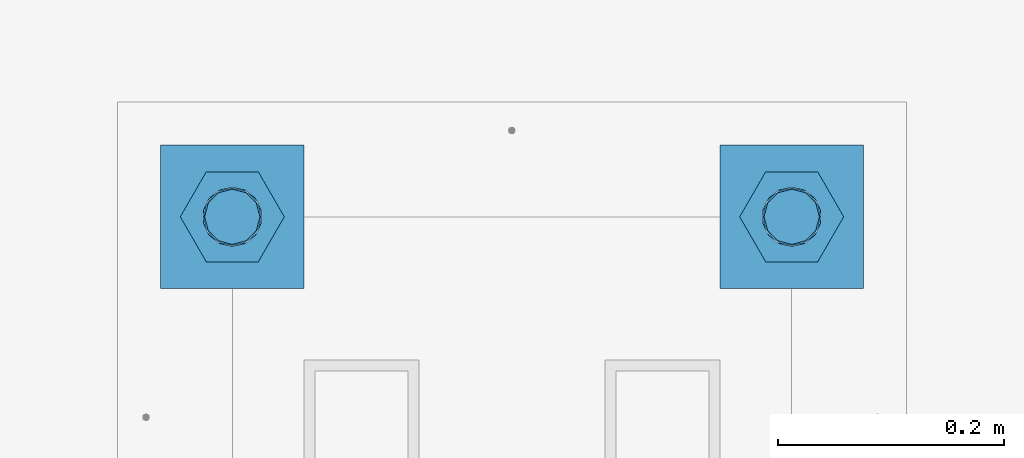
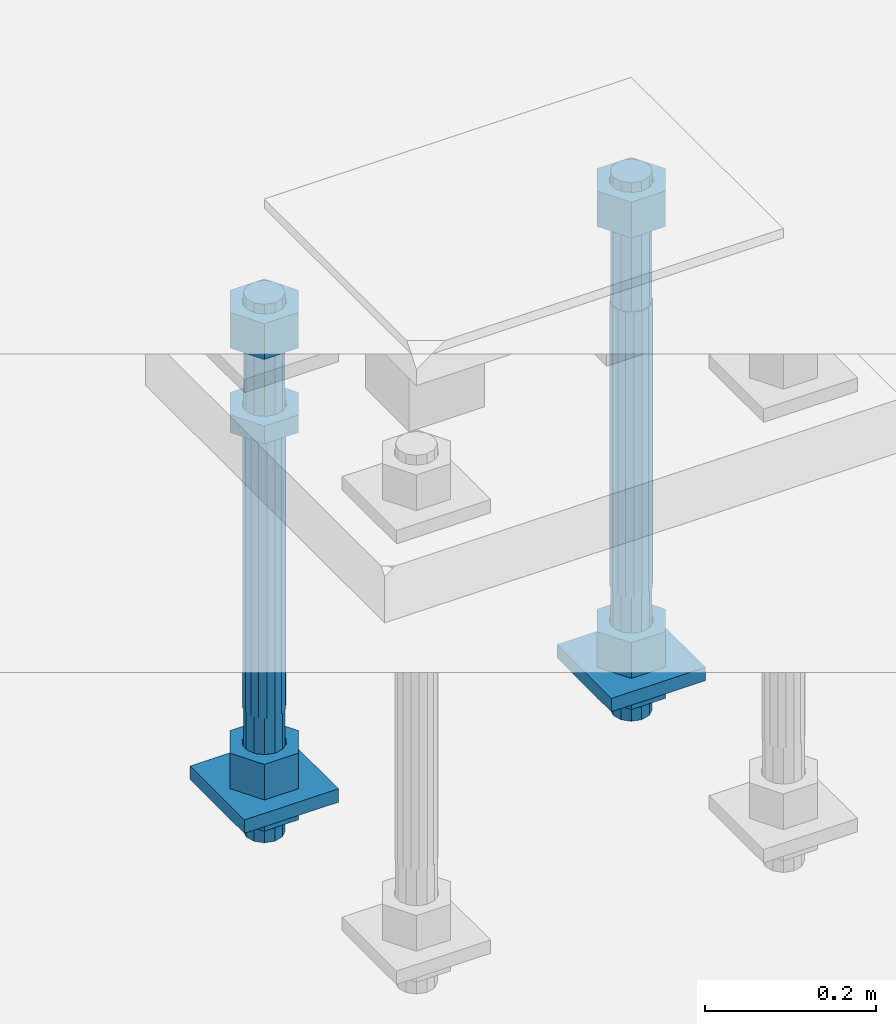
# One storey, part 2705 of 3843: 11 beams, 1 element without a shape of its own.
"""IFC2X3 building model written with IfcOpenShell, lengths in millimetres."""

from ifc_helpers import new_model, si_unit, frame, origin_with_axes, place, context, subcontext, project, spatial, faceted_brep, material, type_object, element, aggregate, save


model = new_model("IFC2X3")

# Units and contexts
model_context = context("Model", 3, precision=1e-05, world=origin_with_axes())
body_context = subcontext(model_context, "Body", "Model", "MODEL_VIEW")
ifc_project = project(units=[si_unit("LENGTHUNIT", "METRE", prefix="MILLI"), si_unit("AREAUNIT", "SQUARE_METRE"), si_unit("VOLUMEUNIT", "CUBIC_METRE"), si_unit("MASSUNIT", "GRAM", prefix="KILO"), si_unit("TIMEUNIT", "SECOND"), si_unit("PLANEANGLEUNIT", "RADIAN"), si_unit("SOLIDANGLEUNIT", "STERADIAN"), si_unit("THERMODYNAMICTEMPERATUREUNIT", "DEGREE_CELSIUS"), si_unit("LUMINOUSINTENSITYUNIT", "LUMEN")], contexts=[model_context])

# Site, building, storey
site_placement = place(None, origin_with_axes())
site = spatial("IfcSite", under=ifc_project, at=site_placement, CompositionType="ELEMENT")
building_placement = place(site_placement, origin_with_axes())
building = spatial("IfcBuilding", under=site, at=building_placement, Name="Undefined", CompositionType="ELEMENT")
storey_placement = place(building_placement, origin_with_axes())
storey = spatial("IfcBuildingStorey", under=building, at=storey_placement, Name="Undefined", CompositionType="ELEMENT", Elevation=0.0)

# Assembly, beams
assembly_placement = place(storey_placement, origin_with_axes())
assembly = element("IfcElementAssembly", 1, at=assembly_placement, inside=storey, Name="TEMPLATE", AssemblyPlace="NOTDEFINED", PredefinedType="RIGID_FRAME")
ifc_material_1 = material(Name="STEEL/A572-50")
beam_type_1 = type_object("IfcBeamType", PredefinedType="NOTDEFINED")
beam_1_placement = place(assembly_placement, frame((105403.65, 45910.4999984741, 29244.925), z_axis=(-1.0, 0.0, 0.0), x_axis=(0.0, -1.0, 0.0)))
beam_1 = element("IfcBeam", 2, at=beam_1_placement, type_object=beam_type_1, material=ifc_material_1, Name="WASHER_PLATE", context=body_context, shape_type="Brep", body=[
    faceted_brep([(0.0, 9.52500000000146, -63.5), (0.0, 9.52500000000146, 63.5), (127.0, 9.52500000000146, 63.5), (127.0, 9.52500000000146, -63.5), (0.0, -9.52500000000146, 63.5), (127.0, -9.52500000000146, 63.5), (0.0, -9.52500000000146, -63.5), (127.0, -9.52500000000146, -63.5)], [[[0, 1, 2, 3]], [[1, 4, 5, 2]], [[4, 6, 7, 5]], [[6, 0, 3, 7]], [[5, 7, 3, 2]], [[6, 4, 1, 0]]]),
])
beam_2_placement = place(assembly_placement, frame((104908.35, 45910.4999984741, 29244.925), z_axis=(-1.0, 0.0, 0.0), x_axis=(0.0, -1.0, 0.0)))
beam_2 = element("IfcBeam", 3, at=beam_2_placement, type_object=beam_type_1, material=ifc_material_1, Name="WASHER_PLATE", context=body_context, shape_type="Brep", body=[
    faceted_brep([(0.0, 9.52500000000146, -63.5), (0.0, 9.52500000000146, 63.5), (127.0, 9.52500000000146, 63.5), (127.0, 9.52500000000146, -63.5), (0.0, -9.52500000000146, 63.5), (127.0, -9.52500000000146, 63.5), (0.0, -9.52500000000146, -63.5), (127.0, -9.52500000000146, -63.5)], [[[0, 1, 2, 3]], [[1, 4, 5, 2]], [[4, 6, 7, 5]], [[6, 0, 3, 7]], [[5, 7, 3, 2]], [[6, 4, 1, 0]]]),
])
ifc_material_2 = material(Name="STEEL/A36")
beam_type_2 = type_object("IfcBeamType", Name="2_HALF_NUT", PredefinedType="NOTDEFINED")
beam_3_placement = place(assembly_placement, frame((105403.65, 45846.9999984741, 29235.4), z_axis=(0.0, -1.0, 0.0), x_axis=(0.0, 0.0, -1.0)))
beam_3 = element("IfcBeam", 4, at=beam_3_placement, type_object=beam_type_2, material=ifc_material_2, Name="NUT", ObjectType="2_HALF_NUT", context=body_context, shape_type="Brep", body=[
    faceted_brep([(0.0, -46.0369987487793, 0.0), (0.0, -23.0184993743896, -39.869213104248), (25.4000000000015, -23.0184993743896, -39.869213104248), (25.4000000000015, -46.0369987487793, 0.0), (0.0, 23.0184993743896, -39.869213104248), (25.4000000000015, 23.0184993743896, -39.869213104248), (0.0, 46.0369987487793, 0.0), (25.4000000000015, 46.0369987487793, 0.0), (0.0, 23.0184993743896, 39.869213104248), (25.4000000000015, 23.0184993743896, 39.869213104248), (0.0, -23.0184993743896, 39.869213104248), (25.4000000000015, -23.0184993743896, 39.869213104248), (0.0, 0.0, 26.1940002441406), (0.0, 11.3650617044477, 23.5999013092805), (25.4000000000015, 11.3650617044477, 23.5999013092805), (25.4000000000015, 0.0, 26.1940002441406), (0.0, 20.4791109456419, 16.3316083006721), (25.4000000000015, 20.4791109456419, 16.3316083006721), (0.0, 25.5370200498292, 5.82867859874386), (25.4000000000015, 25.5370200498292, 5.82867859874386), (0.0, 25.5370200498292, -5.82867859874386), (25.4000000000015, 25.5370200498292, -5.82867859874386), (0.0, 20.4791109456419, -16.3316083006721), (25.4000000000015, 20.4791109456419, -16.3316083006721), (0.0, 11.3650617044477, -23.5999013092805), (25.4000000000015, 11.3650617044477, -23.5999013092805), (0.0, 0.0, -26.1940002441406), (25.4000000000015, 0.0, -26.1940002441406), (0.0, -11.3650617044477, -23.5999013092805), (25.4000000000015, -11.3650617044477, -23.5999013092805), (0.0, -20.4791109456419, -16.3316083006721), (25.4000000000015, -20.4791109456419, -16.3316083006721), (0.0, -25.5370200498292, -5.82867859874386), (25.4000000000015, -25.5370200498292, -5.82867859874386), (0.0, -25.5370200498292, 5.82867859874386), (25.4000000000015, -25.5370200498292, 5.82867859874386), (0.0, -20.4791109456419, 16.3316083006721), (25.4000000000015, -20.4791109456419, 16.3316083006721), (0.0, -11.3650617044477, 23.5999013092805), (25.4000000000015, -11.3650617044477, 23.5999013092805)], [[[0, 1, 2, 3]], [[1, 4, 5, 2]], [[4, 6, 7, 5]], [[6, 8, 9, 7]], [[8, 10, 11, 9]], [[10, 0, 3, 11]], [[12, 13, 14, 15]], [[13, 16, 17, 14]], [[16, 18, 19, 17]], [[18, 20, 21, 19]], [[20, 22, 23, 21]], [[22, 24, 25, 23]], [[24, 26, 27, 25]], [[26, 28, 29, 27]], [[28, 30, 31, 29]], [[30, 32, 33, 31]], [[32, 34, 35, 33]], [[34, 36, 37, 35]], [[36, 38, 39, 37]], [[38, 12, 15, 39]], [[5, 7, 9, 11, 3, 2], [17, 19, 21, 23, 25, 27, 29, 31, 33, 35, 37, 39, 15, 14]], [[10, 8, 6, 4, 1, 0], [38, 36, 34, 32, 30, 28, 26, 24, 22, 20, 18, 16, 13, 12]]]),
])
beam_4_placement = place(assembly_placement, frame((104908.35, 45846.9999984741, 29787.85), z_axis=(0.0, -1.0, 0.0), x_axis=(0.0, 0.0, -1.0)))
beam_4 = element("IfcBeam", 5, at=beam_4_placement, type_object=beam_type_2, material=ifc_material_2, Name="NUT", ObjectType="2_HALF_NUT", context=body_context, shape_type="Brep", body=[
    faceted_brep([(0.0, -46.0369987487793, 0.0), (0.0, -23.0184993743896, -39.869213104248), (25.4000000000015, -23.0184993743896, -39.869213104248), (25.4000000000015, -46.0369987487793, 0.0), (0.0, 23.0184993743896, -39.869213104248), (25.4000000000015, 23.0184993743896, -39.869213104248), (0.0, 46.0369987487793, 0.0), (25.4000000000015, 46.0369987487793, 0.0), (0.0, 23.0184993743896, 39.869213104248), (25.4000000000015, 23.0184993743896, 39.869213104248), (0.0, -23.0184993743896, 39.869213104248), (25.4000000000015, -23.0184993743896, 39.869213104248), (0.0, 0.0, 26.1940002441406), (0.0, 11.3650617044477, 23.5999013092805), (25.4000000000015, 11.3650617044477, 23.5999013092805), (25.4000000000015, 0.0, 26.1940002441406), (0.0, 20.4791109456419, 16.3316083006721), (25.4000000000015, 20.4791109456419, 16.3316083006721), (0.0, 25.5370200498292, 5.82867859874386), (25.4000000000015, 25.5370200498292, 5.82867859874386), (0.0, 25.5370200498292, -5.82867859874386), (25.4000000000015, 25.5370200498292, -5.82867859874386), (0.0, 20.4791109456419, -16.3316083006721), (25.4000000000015, 20.4791109456419, -16.3316083006721), (0.0, 11.3650617044477, -23.5999013092805), (25.4000000000015, 11.3650617044477, -23.5999013092805), (0.0, 0.0, -26.1940002441406), (25.4000000000015, 0.0, -26.1940002441406), (0.0, -11.3650617044477, -23.5999013092805), (25.4000000000015, -11.3650617044477, -23.5999013092805), (0.0, -20.4791109456419, -16.3316083006721), (25.4000000000015, -20.4791109456419, -16.3316083006721), (0.0, -25.5370200498292, -5.82867859874386), (25.4000000000015, -25.5370200498292, -5.82867859874386), (0.0, -25.5370200498292, 5.82867859874386), (25.4000000000015, -25.5370200498292, 5.82867859874386), (0.0, -20.4791109456419, 16.3316083006721), (25.4000000000015, -20.4791109456419, 16.3316083006721), (0.0, -11.3650617044477, 23.5999013092805), (25.4000000000015, -11.3650617044477, 23.5999013092805)], [[[0, 1, 2, 3]], [[1, 4, 5, 2]], [[4, 6, 7, 5]], [[6, 8, 9, 7]], [[8, 10, 11, 9]], [[10, 0, 3, 11]], [[12, 13, 14, 15]], [[13, 16, 17, 14]], [[16, 18, 19, 17]], [[18, 20, 21, 19]], [[20, 22, 23, 21]], [[22, 24, 25, 23]], [[24, 26, 27, 25]], [[26, 28, 29, 27]], [[28, 30, 31, 29]], [[30, 32, 33, 31]], [[32, 34, 35, 33]], [[34, 36, 37, 35]], [[36, 38, 39, 37]], [[38, 12, 15, 39]], [[5, 7, 9, 11, 3, 2], [17, 19, 21, 23, 25, 27, 29, 31, 33, 35, 37, 39, 15, 14]], [[10, 8, 6, 4, 1, 0], [38, 36, 34, 32, 30, 28, 26, 24, 22, 20, 18, 16, 13, 12]]]),
])
beam_5_placement = place(assembly_placement, frame((104908.35, 45846.9999984741, 29235.4), z_axis=(0.0, -1.0, 0.0), x_axis=(0.0, 0.0, -1.0)))
beam_5 = element("IfcBeam", 6, at=beam_5_placement, type_object=beam_type_2, material=ifc_material_2, Name="NUT", ObjectType="2_HALF_NUT", context=body_context, shape_type="Brep", body=[
    faceted_brep([(0.0, -46.0369987487793, 0.0), (0.0, -23.0184993743896, -39.869213104248), (25.4000000000015, -23.0184993743896, -39.869213104248), (25.4000000000015, -46.0369987487793, 0.0), (0.0, 23.0184993743896, -39.869213104248), (25.4000000000015, 23.0184993743896, -39.869213104248), (0.0, 46.0369987487793, 0.0), (25.4000000000015, 46.0369987487793, 0.0), (0.0, 23.0184993743896, 39.869213104248), (25.4000000000015, 23.0184993743896, 39.869213104248), (0.0, -23.0184993743896, 39.869213104248), (25.4000000000015, -23.0184993743896, 39.869213104248), (0.0, 0.0, 26.1940002441406), (0.0, 11.3650617044477, 23.5999013092805), (25.4000000000015, 11.3650617044477, 23.5999013092805), (25.4000000000015, 0.0, 26.1940002441406), (0.0, 20.4791109456419, 16.3316083006721), (25.4000000000015, 20.4791109456419, 16.3316083006721), (0.0, 25.5370200498292, 5.82867859874386), (25.4000000000015, 25.5370200498292, 5.82867859874386), (0.0, 25.5370200498292, -5.82867859874386), (25.4000000000015, 25.5370200498292, -5.82867859874386), (0.0, 20.4791109456419, -16.3316083006721), (25.4000000000015, 20.4791109456419, -16.3316083006721), (0.0, 11.3650617044477, -23.5999013092805), (25.4000000000015, 11.3650617044477, -23.5999013092805), (0.0, 0.0, -26.1940002441406), (25.4000000000015, 0.0, -26.1940002441406), (0.0, -11.3650617044477, -23.5999013092805), (25.4000000000015, -11.3650617044477, -23.5999013092805), (0.0, -20.4791109456419, -16.3316083006721), (25.4000000000015, -20.4791109456419, -16.3316083006721), (0.0, -25.5370200498292, -5.82867859874386), (25.4000000000015, -25.5370200498292, -5.82867859874386), (0.0, -25.5370200498292, 5.82867859874386), (25.4000000000015, -25.5370200498292, 5.82867859874386), (0.0, -20.4791109456419, 16.3316083006721), (25.4000000000015, -20.4791109456419, 16.3316083006721), (0.0, -11.3650617044477, 23.5999013092805), (25.4000000000015, -11.3650617044477, 23.5999013092805)], [[[0, 1, 2, 3]], [[1, 4, 5, 2]], [[4, 6, 7, 5]], [[6, 8, 9, 7]], [[8, 10, 11, 9]], [[10, 0, 3, 11]], [[12, 13, 14, 15]], [[13, 16, 17, 14]], [[16, 18, 19, 17]], [[18, 20, 21, 19]], [[20, 22, 23, 21]], [[22, 24, 25, 23]], [[24, 26, 27, 25]], [[26, 28, 29, 27]], [[28, 30, 31, 29]], [[30, 32, 33, 31]], [[32, 34, 35, 33]], [[34, 36, 37, 35]], [[36, 38, 39, 37]], [[38, 12, 15, 39]], [[5, 7, 9, 11, 3, 2], [17, 19, 21, 23, 25, 27, 29, 31, 33, 35, 37, 39, 15, 14]], [[10, 8, 6, 4, 1, 0], [38, 36, 34, 32, 30, 28, 26, 24, 22, 20, 18, 16, 13, 12]]]),
])
beam_type_3 = type_object("IfcBeamType", Name="2_HEAVY_HEX_NUT", PredefinedType="NOTDEFINED")
beam_6_placement = place(assembly_placement, frame((105403.65, 45846.9999984741, 29933.9), z_axis=(0.0, -1.0, 0.0), x_axis=(0.0, 0.0, -1.0)))
beam_6 = element("IfcBeam", 7, at=beam_6_placement, type_object=beam_type_3, material=ifc_material_2, Name="NUT", ObjectType="2_HEAVY_HEX_NUT", context=body_context, shape_type="Brep", body=[
    faceted_brep([(0.0, -46.0369987487793, 0.0), (0.0, -23.0184993743896, -39.869213104248), (50.7999999999993, -23.0184993743896, -39.869213104248), (50.7999999999993, -46.0369987487793, 0.0), (0.0, 23.0184993743896, -39.869213104248), (50.7999999999993, 23.0184993743896, -39.869213104248), (0.0, 46.0369987487793, 0.0), (50.7999999999993, 46.0369987487793, 0.0), (0.0, 23.0184993743896, 39.869213104248), (50.7999999999993, 23.0184993743896, 39.869213104248), (0.0, -23.0184993743896, 39.869213104248), (50.7999999999993, -23.0184993743896, 39.869213104248), (0.0, 0.0, 26.1940002441406), (0.0, 11.3650617044477, 23.5999013092805), (50.7999999999993, 11.3650617044477, 23.5999013092805), (50.7999999999993, 0.0, 26.1940002441406), (0.0, 20.4791109456419, 16.3316083006721), (50.7999999999993, 20.4791109456419, 16.3316083006721), (0.0, 25.5370200498292, 5.82867859874386), (50.7999999999993, 25.5370200498292, 5.82867859874386), (0.0, 25.5370200498292, -5.82867859874386), (50.7999999999993, 25.5370200498292, -5.82867859874386), (0.0, 20.4791109456419, -16.3316083006721), (50.7999999999993, 20.4791109456419, -16.3316083006721), (0.0, 11.3650617044477, -23.5999013092805), (50.7999999999993, 11.3650617044477, -23.5999013092805), (0.0, 0.0, -26.1940002441406), (50.7999999999993, 0.0, -26.1940002441406), (0.0, -11.3650617044477, -23.5999013092805), (50.7999999999993, -11.3650617044477, -23.5999013092805), (0.0, -20.4791109456419, -16.3316083006721), (50.7999999999993, -20.4791109456419, -16.3316083006721), (0.0, -25.5370200498292, -5.82867859874386), (50.7999999999993, -25.5370200498292, -5.82867859874386), (0.0, -25.5370200498292, 5.82867859874386), (50.7999999999993, -25.5370200498292, 5.82867859874386), (0.0, -20.4791109456419, 16.3316083006721), (50.7999999999993, -20.4791109456419, 16.3316083006721), (0.0, -11.3650617044477, 23.5999013092805), (50.7999999999993, -11.3650617044477, 23.5999013092805)], [[[0, 1, 2, 3]], [[1, 4, 5, 2]], [[4, 6, 7, 5]], [[6, 8, 9, 7]], [[8, 10, 11, 9]], [[10, 0, 3, 11]], [[12, 13, 14, 15]], [[13, 16, 17, 14]], [[16, 18, 19, 17]], [[18, 20, 21, 19]], [[20, 22, 23, 21]], [[22, 24, 25, 23]], [[24, 26, 27, 25]], [[26, 28, 29, 27]], [[28, 30, 31, 29]], [[30, 32, 33, 31]], [[32, 34, 35, 33]], [[34, 36, 37, 35]], [[36, 38, 39, 37]], [[38, 12, 15, 39]], [[5, 7, 9, 11, 3, 2], [17, 19, 21, 23, 25, 27, 29, 31, 33, 35, 37, 39, 15, 14]], [[10, 8, 6, 4, 1, 0], [38, 36, 34, 32, 30, 28, 26, 24, 22, 20, 18, 16, 13, 12]]]),
])
beam_7_placement = place(assembly_placement, frame((105403.65, 45846.9999984741, 29305.25), z_axis=(0.0, -1.0, 0.0), x_axis=(0.0, 0.0, -1.0)))
beam_7 = element("IfcBeam", 8, at=beam_7_placement, type_object=beam_type_3, material=ifc_material_2, Name="NUT", ObjectType="2_HEAVY_HEX_NUT", context=body_context, shape_type="Brep", body=[
    faceted_brep([(0.0, -46.0369987487793, 0.0), (0.0, -23.0184993743896, -39.869213104248), (50.7999999999993, -23.0184993743896, -39.869213104248), (50.7999999999993, -46.0369987487793, 0.0), (0.0, 23.0184993743896, -39.869213104248), (50.7999999999993, 23.0184993743896, -39.869213104248), (0.0, 46.0369987487793, 0.0), (50.7999999999993, 46.0369987487793, 0.0), (0.0, 23.0184993743896, 39.869213104248), (50.7999999999993, 23.0184993743896, 39.869213104248), (0.0, -23.0184993743896, 39.869213104248), (50.7999999999993, -23.0184993743896, 39.869213104248), (0.0, 0.0, 26.1940002441406), (0.0, 11.3650617044477, 23.5999013092805), (50.7999999999993, 11.3650617044477, 23.5999013092805), (50.7999999999993, 0.0, 26.1940002441406), (0.0, 20.4791109456419, 16.3316083006721), (50.7999999999993, 20.4791109456419, 16.3316083006721), (0.0, 25.5370200498292, 5.82867859874386), (50.7999999999993, 25.5370200498292, 5.82867859874386), (0.0, 25.5370200498292, -5.82867859874386), (50.7999999999993, 25.5370200498292, -5.82867859874386), (0.0, 20.4791109456419, -16.3316083006721), (50.7999999999993, 20.4791109456419, -16.3316083006721), (0.0, 11.3650617044477, -23.5999013092805), (50.7999999999993, 11.3650617044477, -23.5999013092805), (0.0, 0.0, -26.1940002441406), (50.7999999999993, 0.0, -26.1940002441406), (0.0, -11.3650617044477, -23.5999013092805), (50.7999999999993, -11.3650617044477, -23.5999013092805), (0.0, -20.4791109456419, -16.3316083006721), (50.7999999999993, -20.4791109456419, -16.3316083006721), (0.0, -25.5370200498292, -5.82867859874386), (50.7999999999993, -25.5370200498292, -5.82867859874386), (0.0, -25.5370200498292, 5.82867859874386), (50.7999999999993, -25.5370200498292, 5.82867859874386), (0.0, -20.4791109456419, 16.3316083006721), (50.7999999999993, -20.4791109456419, 16.3316083006721), (0.0, -11.3650617044477, 23.5999013092805), (50.7999999999993, -11.3650617044477, 23.5999013092805)], [[[0, 1, 2, 3]], [[1, 4, 5, 2]], [[4, 6, 7, 5]], [[6, 8, 9, 7]], [[8, 10, 11, 9]], [[10, 0, 3, 11]], [[12, 13, 14, 15]], [[13, 16, 17, 14]], [[16, 18, 19, 17]], [[18, 20, 21, 19]], [[20, 22, 23, 21]], [[22, 24, 25, 23]], [[24, 26, 27, 25]], [[26, 28, 29, 27]], [[28, 30, 31, 29]], [[30, 32, 33, 31]], [[32, 34, 35, 33]], [[34, 36, 37, 35]], [[36, 38, 39, 37]], [[38, 12, 15, 39]], [[5, 7, 9, 11, 3, 2], [17, 19, 21, 23, 25, 27, 29, 31, 33, 35, 37, 39, 15, 14]], [[10, 8, 6, 4, 1, 0], [38, 36, 34, 32, 30, 28, 26, 24, 22, 20, 18, 16, 13, 12]]]),
])
beam_8_placement = place(assembly_placement, frame((104908.35, 45846.9999984741, 29933.9), z_axis=(0.0, -1.0, 0.0), x_axis=(0.0, 0.0, -1.0)))
beam_8 = element("IfcBeam", 9, at=beam_8_placement, type_object=beam_type_3, material=ifc_material_2, Name="NUT", ObjectType="2_HEAVY_HEX_NUT", context=body_context, shape_type="Brep", body=[
    faceted_brep([(0.0, -46.0369987487793, 0.0), (0.0, -23.0184993743896, -39.869213104248), (50.7999999999993, -23.0184993743896, -39.869213104248), (50.7999999999993, -46.0369987487793, 0.0), (0.0, 23.0184993743896, -39.869213104248), (50.7999999999993, 23.0184993743896, -39.869213104248), (0.0, 46.0369987487793, 0.0), (50.7999999999993, 46.0369987487793, 0.0), (0.0, 23.0184993743896, 39.869213104248), (50.7999999999993, 23.0184993743896, 39.869213104248), (0.0, -23.0184993743896, 39.869213104248), (50.7999999999993, -23.0184993743896, 39.869213104248), (0.0, 0.0, 26.1940002441406), (0.0, 11.3650617044477, 23.5999013092805), (50.7999999999993, 11.3650617044477, 23.5999013092805), (50.7999999999993, 0.0, 26.1940002441406), (0.0, 20.4791109456419, 16.3316083006721), (50.7999999999993, 20.4791109456419, 16.3316083006721), (0.0, 25.5370200498292, 5.82867859874386), (50.7999999999993, 25.5370200498292, 5.82867859874386), (0.0, 25.5370200498292, -5.82867859874386), (50.7999999999993, 25.5370200498292, -5.82867859874386), (0.0, 20.4791109456419, -16.3316083006721), (50.7999999999993, 20.4791109456419, -16.3316083006721), (0.0, 11.3650617044477, -23.5999013092805), (50.7999999999993, 11.3650617044477, -23.5999013092805), (0.0, 0.0, -26.1940002441406), (50.7999999999993, 0.0, -26.1940002441406), (0.0, -11.3650617044477, -23.5999013092805), (50.7999999999993, -11.3650617044477, -23.5999013092805), (0.0, -20.4791109456419, -16.3316083006721), (50.7999999999993, -20.4791109456419, -16.3316083006721), (0.0, -25.5370200498292, -5.82867859874386), (50.7999999999993, -25.5370200498292, -5.82867859874386), (0.0, -25.5370200498292, 5.82867859874386), (50.7999999999993, -25.5370200498292, 5.82867859874386), (0.0, -20.4791109456419, 16.3316083006721), (50.7999999999993, -20.4791109456419, 16.3316083006721), (0.0, -11.3650617044477, 23.5999013092805), (50.7999999999993, -11.3650617044477, 23.5999013092805)], [[[0, 1, 2, 3]], [[1, 4, 5, 2]], [[4, 6, 7, 5]], [[6, 8, 9, 7]], [[8, 10, 11, 9]], [[10, 0, 3, 11]], [[12, 13, 14, 15]], [[13, 16, 17, 14]], [[16, 18, 19, 17]], [[18, 20, 21, 19]], [[20, 22, 23, 21]], [[22, 24, 25, 23]], [[24, 26, 27, 25]], [[26, 28, 29, 27]], [[28, 30, 31, 29]], [[30, 32, 33, 31]], [[32, 34, 35, 33]], [[34, 36, 37, 35]], [[36, 38, 39, 37]], [[38, 12, 15, 39]], [[5, 7, 9, 11, 3, 2], [17, 19, 21, 23, 25, 27, 29, 31, 33, 35, 37, 39, 15, 14]], [[10, 8, 6, 4, 1, 0], [38, 36, 34, 32, 30, 28, 26, 24, 22, 20, 18, 16, 13, 12]]]),
])
beam_9_placement = place(assembly_placement, frame((104908.35, 45846.9999984741, 29305.25), z_axis=(0.0, -1.0, 0.0), x_axis=(0.0, 0.0, -1.0)))
beam_9 = element("IfcBeam", 10, at=beam_9_placement, type_object=beam_type_3, material=ifc_material_2, Name="NUT", ObjectType="2_HEAVY_HEX_NUT", context=body_context, shape_type="Brep", body=[
    faceted_brep([(0.0, -46.0369987487793, 0.0), (0.0, -23.0184993743896, -39.869213104248), (50.7999999999993, -23.0184993743896, -39.869213104248), (50.7999999999993, -46.0369987487793, 0.0), (0.0, 23.0184993743896, -39.869213104248), (50.7999999999993, 23.0184993743896, -39.869213104248), (0.0, 46.0369987487793, 0.0), (50.7999999999993, 46.0369987487793, 0.0), (0.0, 23.0184993743896, 39.869213104248), (50.7999999999993, 23.0184993743896, 39.869213104248), (0.0, -23.0184993743896, 39.869213104248), (50.7999999999993, -23.0184993743896, 39.869213104248), (0.0, 0.0, 26.1940002441406), (0.0, 11.3650617044477, 23.5999013092805), (50.7999999999993, 11.3650617044477, 23.5999013092805), (50.7999999999993, 0.0, 26.1940002441406), (0.0, 20.4791109456419, 16.3316083006721), (50.7999999999993, 20.4791109456419, 16.3316083006721), (0.0, 25.5370200498292, 5.82867859874386), (50.7999999999993, 25.5370200498292, 5.82867859874386), (0.0, 25.5370200498292, -5.82867859874386), (50.7999999999993, 25.5370200498292, -5.82867859874386), (0.0, 20.4791109456419, -16.3316083006721), (50.7999999999993, 20.4791109456419, -16.3316083006721), (0.0, 11.3650617044477, -23.5999013092805), (50.7999999999993, 11.3650617044477, -23.5999013092805), (0.0, 0.0, -26.1940002441406), (50.7999999999993, 0.0, -26.1940002441406), (0.0, -11.3650617044477, -23.5999013092805), (50.7999999999993, -11.3650617044477, -23.5999013092805), (0.0, -20.4791109456419, -16.3316083006721), (50.7999999999993, -20.4791109456419, -16.3316083006721), (0.0, -25.5370200498292, -5.82867859874386), (50.7999999999993, -25.5370200498292, -5.82867859874386), (0.0, -25.5370200498292, 5.82867859874386), (50.7999999999993, -25.5370200498292, 5.82867859874386), (0.0, -20.4791109456419, 16.3316083006721), (50.7999999999993, -20.4791109456419, 16.3316083006721), (0.0, -11.3650617044477, 23.5999013092805), (50.7999999999993, -11.3650617044477, 23.5999013092805)], [[[0, 1, 2, 3]], [[1, 4, 5, 2]], [[4, 6, 7, 5]], [[6, 8, 9, 7]], [[8, 10, 11, 9]], [[10, 0, 3, 11]], [[12, 13, 14, 15]], [[13, 16, 17, 14]], [[16, 18, 19, 17]], [[18, 20, 21, 19]], [[20, 22, 23, 21]], [[22, 24, 25, 23]], [[24, 26, 27, 25]], [[26, 28, 29, 27]], [[28, 30, 31, 29]], [[30, 32, 33, 31]], [[32, 34, 35, 33]], [[34, 36, 37, 35]], [[36, 38, 39, 37]], [[38, 12, 15, 39]], [[5, 7, 9, 11, 3, 2], [17, 19, 21, 23, 25, 27, 29, 31, 33, 35, 37, 39, 15, 14]], [[10, 8, 6, 4, 1, 0], [38, 36, 34, 32, 30, 28, 26, 24, 22, 20, 18, 16, 13, 12]]]),
])
ifc_material_3 = material()
beam_type_4 = type_object("IfcBeamType", PredefinedType="NOTDEFINED")
beam_10_placement = place(assembly_placement, frame((105403.65, 45846.9999984741, 29762.45), z_axis=(0.0, -1.0, 0.0), x_axis=(0.0, 0.0, -1.0)))
beam_10 = element("IfcBeam", 11, at=beam_10_placement, type_object=beam_type_4, material=ifc_material_3, Name="ANCHOR_ROD", context=body_context, shape_type="Brep", body=[
    faceted_brep([(-184.150000000001, -21.217622392709, 12.25), (-184.150000000001, -12.2499999999854, 21.2176223927163), (-184.150000000001, 1.45519152283669e-11, 24.5), (-184.150000000001, 12.2500000000146, 21.2176223927163), (-184.150000000001, 21.2176223927381, 12.25), (-184.150000000001, 24.5000000000146, 0.0), (-184.150000000001, 21.2176223927381, -12.25), (-184.150000000001, 12.2500000000146, -21.2176223927163), (-184.150000000001, 1.45519152283669e-11, -24.5), (-184.150000000001, -12.2499999999854, -21.2176223927163), (-184.150000000001, -21.217622392709, -12.25), (-184.150000000001, -24.4999999999854, 0.0), (0.0, 24.5000000000146, 0.0), (0.0, 21.2176223927381, -12.25), (0.0, 12.2500000000146, -21.2176223927163), (0.0, 1.45519152283669e-11, -24.5), (0.0, -12.2499999999854, -21.2176223927163), (0.0, -21.217622392709, -12.25), (0.0, -24.4999999999854, 0.0), (0.0, -21.217622392709, 12.25), (0.0, -12.2499999999854, 21.2176223927163), (0.0, 1.45519152283669e-11, 24.5), (0.0, 12.2500000000146, 21.2176223927163), (0.0, 21.2176223927381, 12.25), (0.0, -23.4665401257807, 9.72015918207035), (0.0, -17.9605122421344, 17.9605122421417), (0.0, -9.72015918207762, 23.466540125788), (0.0, 0.0, 25.4000000000015), (0.0, 9.72015918207762, 23.466540125788), (0.0, 17.9605122421344, 17.9605122421417), (0.0, 23.4665401257807, 9.72015918207035), (0.0, 25.3999996185303, 0.0), (0.0, 23.4665401257807, -9.72015918207035), (0.0, 17.9605122421344, -17.9605122421417), (0.0, 9.72015918207762, -23.466540125788), (0.0, 0.0, -25.4000000000015), (0.0, -9.72015918207762, -23.466540125788), (0.0, -17.9605122421344, -17.9605122421417), (0.0, -23.4665401257807, -9.72015918207035), (0.0, -25.3999996185303, 0.0), (406.399999999998, -25.3999999999942, 0.0), (406.399999999998, -23.4665401257807, 9.72015918207035), (406.399999999998, -17.9605122421344, 17.9605122421417), (406.399999999998, -9.72015918207762, 23.466540125788), (406.399999999998, 0.0, 25.4000000000015), (406.399999999998, 9.72015918207762, 23.466540125788), (406.399999999998, 17.9605122421344, 17.9605122421417), (406.399999999998, 23.4665401257807, 9.72015918207035), (406.399999999998, 25.3999999999942, 0.0), (406.399999999998, 23.4665401257807, -9.72015918207035), (406.399999999998, 17.9605122421344, -17.9605122421417), (406.399999999998, 9.72015918207762, -23.466540125788), (406.399999999998, 0.0, -25.4000000000015), (406.399999999998, -9.72015918207762, -23.466540125788), (406.399999999998, -17.9605122421344, -17.9605122421417), (406.399999999998, -23.4665401257807, -9.72015918207035), (406.399999999998, -12.2499999999854, 21.2176223927163), (406.399999999998, 1.45519152283669e-11, 24.5), (406.399999999998, 12.2500000000146, 21.2176223927163), (406.399999999998, 21.2176223927381, 12.25), (406.399999999998, 24.5000000000146, 0.0), (406.399999999998, 21.2176223927381, -12.25), (406.399999999998, 12.2500000000146, -21.2176223927163), (406.399999999998, 1.45519152283669e-11, -24.5), (406.399999999998, -12.2499999999854, -21.2176223927163), (406.399999999998, -21.217622392709, -12.25), (406.399999999998, -24.4999999999854, 0.0), (406.399999999998, -21.217622392709, 12.25), (584.200000000001, -12.2499999999854, -21.2176223927163), (584.200000000001, 1.45519152283669e-11, -24.5), (584.200000000001, 12.2500000000146, -21.2176223927163), (584.200000000001, 21.2176223927381, -12.25), (584.200000000001, 24.5000000000146, 0.0), (584.200000000001, 21.2176223927381, 12.25), (584.200000000001, 12.2500000000146, 21.2176223927163), (584.200000000001, 1.45519152283669e-11, 24.5), (584.200000000001, -12.2499999999854, 21.2176223927163), (584.200000000001, -21.217622392709, 12.25), (584.200000000001, -24.4999999999854, 0.0), (584.200000000001, -21.217622392709, -12.25)], [[[0, 1, 2, 3, 4, 5, 6, 7, 8, 9, 10, 11]], [[6, 5, 12, 13]], [[7, 6, 13, 14]], [[8, 7, 14, 15]], [[9, 8, 15, 16]], [[10, 9, 16, 17]], [[11, 10, 17, 18]], [[0, 11, 18, 19]], [[1, 0, 19, 20]], [[2, 1, 20, 21]], [[3, 2, 21, 22]], [[4, 3, 22, 23]], [[5, 4, 23, 12]], [[24, 25, 26, 27, 28, 29, 30, 31, 32, 33, 34, 35, 36, 37, 38, 39], [22, 21, 20, 19, 18, 17, 16, 15, 14, 13, 12, 23]], [[24, 39, 40, 41]], [[25, 24, 41, 42]], [[26, 25, 42, 43]], [[27, 26, 43, 44]], [[28, 27, 44, 45]], [[29, 28, 45, 46]], [[30, 29, 46, 47]], [[31, 30, 47, 48]], [[32, 31, 48, 49]], [[33, 32, 49, 50]], [[34, 33, 50, 51]], [[35, 34, 51, 52]], [[36, 35, 52, 53]], [[37, 36, 53, 54]], [[38, 37, 54, 55]], [[39, 38, 55, 40]], [[54, 53, 52, 51, 50, 49, 48, 47, 46, 45, 44, 43, 42, 41, 40, 55], [56, 57, 58, 59, 60, 61, 62, 63, 64, 65, 66, 67]], [[68, 69, 70, 71, 72, 73, 74, 75, 76, 77, 78, 79]], [[76, 75, 57, 56]], [[77, 76, 56, 67]], [[78, 77, 67, 66]], [[79, 78, 66, 65]], [[68, 79, 65, 64]], [[69, 68, 64, 63]], [[70, 69, 63, 62]], [[71, 70, 62, 61]], [[72, 71, 61, 60]], [[73, 72, 60, 59]], [[74, 73, 59, 58]], [[75, 74, 58, 57]]]),
])
beam_11_placement = place(assembly_placement, frame((104908.35, 45846.9999984741, 29762.45), z_axis=(0.0, -1.0, 0.0), x_axis=(0.0, 0.0, -1.0)))
beam_11 = element("IfcBeam", 12, at=beam_11_placement, type_object=beam_type_4, material=ifc_material_3, Name="ANCHOR_ROD", context=body_context, shape_type="Brep", body=[
    faceted_brep([(-184.150000000001, -21.217622392709, 12.25), (-184.150000000001, -12.2499999999854, 21.2176223927163), (-184.150000000001, 1.45519152283669e-11, 24.5), (-184.150000000001, 12.2500000000146, 21.2176223927163), (-184.150000000001, 21.2176223927381, 12.25), (-184.150000000001, 24.5000000000146, 0.0), (-184.150000000001, 21.2176223927381, -12.25), (-184.150000000001, 12.2500000000146, -21.2176223927163), (-184.150000000001, 1.45519152283669e-11, -24.5), (-184.150000000001, -12.2499999999854, -21.2176223927163), (-184.150000000001, -21.217622392709, -12.25), (-184.150000000001, -24.4999999999854, 0.0), (0.0, 24.5000000000146, 0.0), (0.0, 21.2176223927381, -12.25), (0.0, 12.2500000000146, -21.2176223927163), (0.0, 1.45519152283669e-11, -24.5), (0.0, -12.2499999999854, -21.2176223927163), (0.0, -21.217622392709, -12.25), (0.0, -24.4999999999854, 0.0), (0.0, -21.217622392709, 12.25), (0.0, -12.2499999999854, 21.2176223927163), (0.0, 1.45519152283669e-11, 24.5), (0.0, 12.2500000000146, 21.2176223927163), (0.0, 21.2176223927381, 12.25), (0.0, -23.4665401257807, 9.72015918207035), (0.0, -17.9605122421344, 17.9605122421417), (0.0, -9.72015918207762, 23.466540125788), (0.0, 0.0, 25.4000000000015), (0.0, 9.72015918207762, 23.466540125788), (0.0, 17.9605122421344, 17.9605122421417), (0.0, 23.4665401257807, 9.72015918207035), (0.0, 25.3999996185303, 0.0), (0.0, 23.4665401257807, -9.72015918207035), (0.0, 17.9605122421344, -17.9605122421417), (0.0, 9.72015918207762, -23.466540125788), (0.0, 0.0, -25.4000000000015), (0.0, -9.72015918207762, -23.466540125788), (0.0, -17.9605122421344, -17.9605122421417), (0.0, -23.4665401257807, -9.72015918207035), (0.0, -25.3999996185303, 0.0), (406.399999999998, -25.3999999999942, 0.0), (406.399999999998, -23.4665401257807, 9.72015918207035), (406.399999999998, -17.9605122421344, 17.9605122421417), (406.399999999998, -9.72015918207762, 23.466540125788), (406.399999999998, 0.0, 25.4000000000015), (406.399999999998, 9.72015918207762, 23.466540125788), (406.399999999998, 17.9605122421344, 17.9605122421417), (406.399999999998, 23.4665401257807, 9.72015918207035), (406.399999999998, 25.3999999999942, 0.0), (406.399999999998, 23.4665401257807, -9.72015918207035), (406.399999999998, 17.9605122421344, -17.9605122421417), (406.399999999998, 9.72015918207762, -23.466540125788), (406.399999999998, 0.0, -25.4000000000015), (406.399999999998, -9.72015918207762, -23.466540125788), (406.399999999998, -17.9605122421344, -17.9605122421417), (406.399999999998, -23.4665401257807, -9.72015918207035), (406.399999999998, -12.2499999999854, 21.2176223927163), (406.399999999998, 1.45519152283669e-11, 24.5), (406.399999999998, 12.2500000000146, 21.2176223927163), (406.399999999998, 21.2176223927381, 12.25), (406.399999999998, 24.5000000000146, 0.0), (406.399999999998, 21.2176223927381, -12.25), (406.399999999998, 12.2500000000146, -21.2176223927163), (406.399999999998, 1.45519152283669e-11, -24.5), (406.399999999998, -12.2499999999854, -21.2176223927163), (406.399999999998, -21.217622392709, -12.25), (406.399999999998, -24.4999999999854, 0.0), (406.399999999998, -21.217622392709, 12.25), (584.200000000001, -12.2499999999854, -21.2176223927163), (584.200000000001, 1.45519152283669e-11, -24.5), (584.200000000001, 12.2500000000146, -21.2176223927163), (584.200000000001, 21.2176223927381, -12.25), (584.200000000001, 24.5000000000146, 0.0), (584.200000000001, 21.2176223927381, 12.25), (584.200000000001, 12.2500000000146, 21.2176223927163), (584.200000000001, 1.45519152283669e-11, 24.5), (584.200000000001, -12.2499999999854, 21.2176223927163), (584.200000000001, -21.217622392709, 12.25), (584.200000000001, -24.4999999999854, 0.0), (584.200000000001, -21.217622392709, -12.25)], [[[0, 1, 2, 3, 4, 5, 6, 7, 8, 9, 10, 11]], [[6, 5, 12, 13]], [[7, 6, 13, 14]], [[8, 7, 14, 15]], [[9, 8, 15, 16]], [[10, 9, 16, 17]], [[11, 10, 17, 18]], [[0, 11, 18, 19]], [[1, 0, 19, 20]], [[2, 1, 20, 21]], [[3, 2, 21, 22]], [[4, 3, 22, 23]], [[5, 4, 23, 12]], [[24, 25, 26, 27, 28, 29, 30, 31, 32, 33, 34, 35, 36, 37, 38, 39], [22, 21, 20, 19, 18, 17, 16, 15, 14, 13, 12, 23]], [[24, 39, 40, 41]], [[25, 24, 41, 42]], [[26, 25, 42, 43]], [[27, 26, 43, 44]], [[28, 27, 44, 45]], [[29, 28, 45, 46]], [[30, 29, 46, 47]], [[31, 30, 47, 48]], [[32, 31, 48, 49]], [[33, 32, 49, 50]], [[34, 33, 50, 51]], [[35, 34, 51, 52]], [[36, 35, 52, 53]], [[37, 36, 53, 54]], [[38, 37, 54, 55]], [[39, 38, 55, 40]], [[54, 53, 52, 51, 50, 49, 48, 47, 46, 45, 44, 43, 42, 41, 40, 55], [56, 57, 58, 59, 60, 61, 62, 63, 64, 65, 66, 67]], [[68, 69, 70, 71, 72, 73, 74, 75, 76, 77, 78, 79]], [[76, 75, 57, 56]], [[77, 76, 56, 67]], [[78, 77, 67, 66]], [[79, 78, 66, 65]], [[68, 79, 65, 64]], [[69, 68, 64, 63]], [[70, 69, 63, 62]], [[71, 70, 62, 61]], [[72, 71, 61, 60]], [[73, 72, 60, 59]], [[74, 73, 59, 58]], [[75, 74, 58, 57]]]),
])
aggregate(assembly, [beam_6, beam_7, beam_3, beam_1, beam_10, beam_4, beam_8, beam_9, beam_5, beam_2, beam_11])

save(model, "model.ifc")
